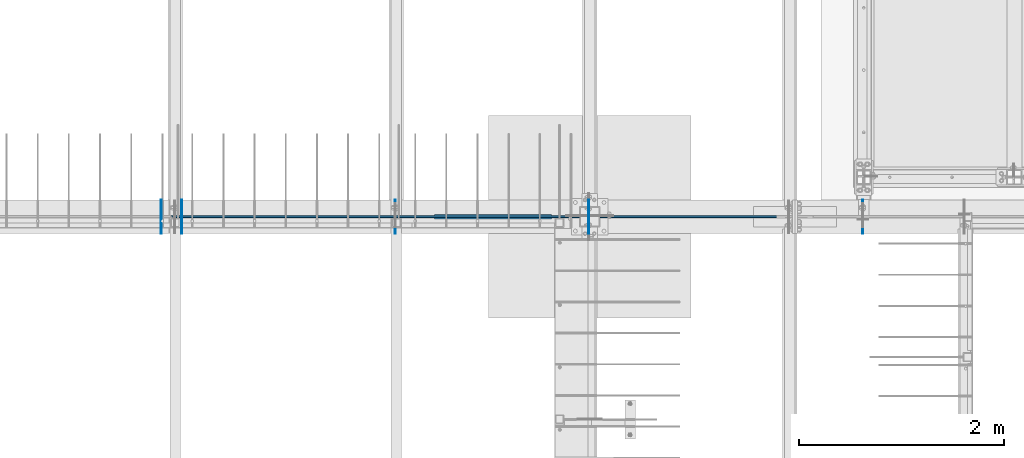
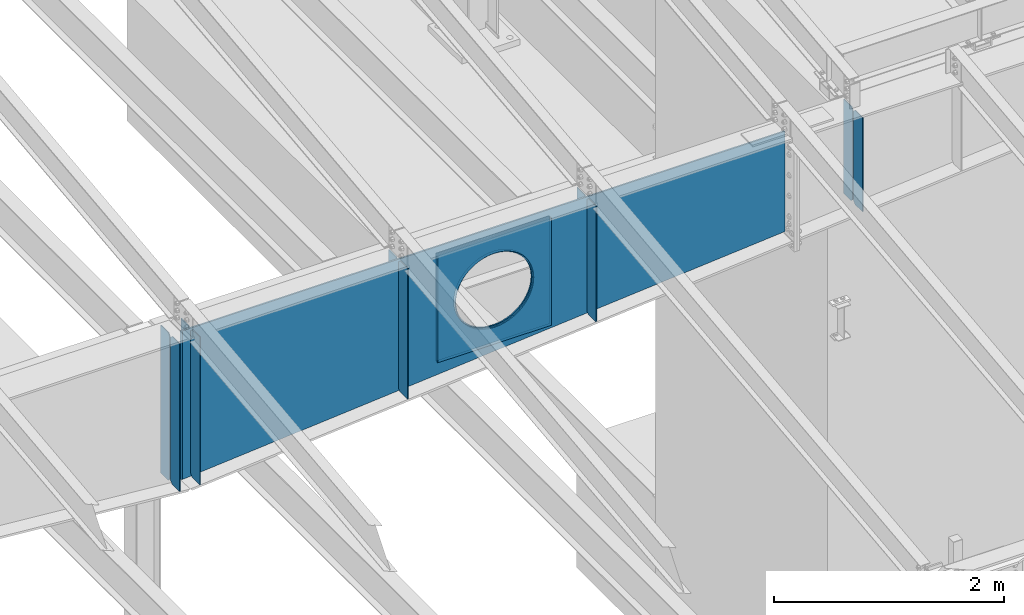
# One storey, part 970 of 1179: 13 plates, 2 elements without a shape of their own.
"""IFC2X3 building model written with IfcOpenShell, lengths in millimetres."""

from ifc_helpers import new_model, si_unit, frame, origin_with_axes, place, context, subcontext, project, spatial, faceted_brep, material, type_object, element, aggregate, save


model = new_model("IFC2X3")

# Units and contexts
model_context = context("Model", 3, precision=1e-05, world=origin_with_axes())
body_context = subcontext(model_context, "Body", "Model", "MODEL_VIEW")
ifc_project = project(units=[si_unit("LENGTHUNIT", "METRE", prefix="MILLI"), si_unit("AREAUNIT", "SQUARE_METRE"), si_unit("VOLUMEUNIT", "CUBIC_METRE"), si_unit("MASSUNIT", "GRAM", prefix="KILO"), si_unit("TIMEUNIT", "SECOND"), si_unit("PLANEANGLEUNIT", "RADIAN"), si_unit("SOLIDANGLEUNIT", "STERADIAN"), si_unit("THERMODYNAMICTEMPERATUREUNIT", "DEGREE_CELSIUS"), si_unit("LUMINOUSINTENSITYUNIT", "LUMEN")], contexts=[model_context])

# Site, building, storey
site_placement = place(None, origin_with_axes())
site = spatial("IfcSite", under=ifc_project, at=site_placement, CompositionType="ELEMENT")
building_placement = place(site_placement, origin_with_axes())
building = spatial("IfcBuilding", under=site, at=building_placement, Name="Undefined", CompositionType="ELEMENT")
storey_placement = place(building_placement, origin_with_axes())
storey = spatial("IfcBuildingStorey", under=building, at=storey_placement, Name="Undefined", CompositionType="ELEMENT", Elevation=0.0)

# Assembly, plates
assembly_1_placement = place(storey_placement, origin_with_axes())
assembly_1 = element("IfcElementAssembly", 1, at=assembly_1_placement, inside=storey, Name="RAFTER BEAM", AssemblyPlace="NOTDEFINED", PredefinedType="RIGID_FRAME")
ifc_material = material(Name="STEEL/A36")
plate_type_1 = type_object("IfcPlateType", PredefinedType="NOTDEFINED")
plate_1_placement = place(assembly_1_placement, frame((14558.9625, 11645.9093353251, 10228.28385672), z_axis=(0.0, 0.0, -1.0), x_axis=(0.0, -1.0, 0.0)))
plate_1 = element("IfcPlate", 2, at=plate_1_placement, type_object=plate_type_1, material=ifc_material, Name="PLATE", context=body_context, shape_type="Brep", body=[
    faceted_brep([(0.0, -4.76249999999709, 0.0), (-3.04256900562905e-06, -4.76250000000073, 1391.55413132619), (-3.04256900562905e-06, 4.76250000000073, 1391.55413132619), (0.0, 4.76249999999709, 0.0), (131.762497338896, -4.76250000000073, 1391.5541316458), (131.762497338896, 4.76250000000073, 1391.5541316458), (157.162497012963, -4.76250000000073, 1366.15413208888), (157.162497012963, 4.76250000000073, 1366.15413208888), (157.162499942613, -4.76250000000073, 25.3999996182793), (157.162499942613, 4.76250000000073, 25.3999996182793), (131.762500381465, -4.76250000000073, -2.09183781407773e-10), (131.762500381465, 4.76250000000073, -2.09183781407773e-10)], [[[0, 1, 2, 3]], [[1, 4, 5, 2]], [[4, 6, 7, 5]], [[6, 8, 9, 7]], [[8, 10, 11, 9]], [[10, 0, 3, 11]], [[5, 7, 9, 11, 3, 2]], [[10, 8, 6, 4, 1, 0]]]),
])
plate_2_placement = place(assembly_1_placement, frame((16451.2625, 11645.9093353251, 10228.28385672), z_axis=(0.0, 0.0, -1.0), x_axis=(0.0, -1.0, 0.0)))
plate_2 = element("IfcPlate", 3, at=plate_2_placement, type_object=plate_type_1, material=ifc_material, Name="PLATE", context=body_context, shape_type="Brep", body=[
    faceted_brep([(0.0, -4.76249999999709, 0.0), (-2.72028773906641e-06, -4.76250000000073, 1230.41295070648), (-2.72028773906641e-06, 4.76250000000073, 1230.41295070648), (0.0, 4.76249999999709, 0.0), (131.762497661177, -4.76250000000073, 1230.41295102609), (131.762497661177, 4.76250000000073, 1230.41295102609), (157.162497335859, -4.76250000000073, 1205.01295146917), (157.162497335859, 4.76250000000073, 1205.01295146917), (157.162499942613, -4.76250000000073, 25.3999996182793), (157.162499942613, 4.76250000000073, 25.3999996182793), (131.762500381465, -4.76250000000073, -2.09183781407773e-10), (131.762500381465, 4.76250000000073, -2.09183781407773e-10)], [[[0, 1, 2, 3]], [[1, 4, 5, 2]], [[4, 6, 7, 5]], [[6, 8, 9, 7]], [[8, 10, 11, 9]], [[10, 0, 3, 11]], [[5, 7, 9, 11, 3, 2]], [[10, 8, 6, 4, 1, 0]]]),
])

# Assembly, plate
assembly_2_placement = place(storey_placement, origin_with_axes())
assembly_2 = element("IfcElementAssembly", 4, at=assembly_2_placement, inside=storey, Name="RAFTER BEAM", AssemblyPlace="NOTDEFINED", PredefinedType="RIGID_FRAME")
plate_3_placement = place(assembly_2_placement, frame((19130.9625, 11645.9093353251, 10228.28385672), z_axis=(0.0, 0.0, -1.0), x_axis=(0.0, -1.0, 0.0)))
plate_3 = element("IfcPlate", 5, at=plate_3_placement, type_object=plate_type_1, material=ifc_material, Name="PLATE", context=body_context, shape_type="Brep", body=[
    faceted_brep([(0.0, -4.76249999999709, 0.0), (-2.26062911679037e-06, -4.76250000000073, 1000.58386493601), (-2.26062911679037e-06, 4.76250000000073, 1000.58386493601), (0.0, 4.76249999999709, 0.0), (131.762498120836, -4.76250000000073, 1000.58386525562), (131.762498120836, 4.76250000000073, 1000.58386525562), (157.162497796751, -4.76250000000073, 975.1838656987), (157.162497796751, 4.76250000000073, 975.1838656987), (157.162499942613, -4.76250000000073, 25.3999996182793), (157.162499942613, 4.76250000000073, 25.3999996182793), (131.762500381465, -4.76250000000073, -2.09183781407773e-10), (131.762500381465, 4.76250000000073, -2.09183781407773e-10)], [[[0, 1, 2, 3]], [[1, 4, 5, 2]], [[4, 6, 7, 5]], [[6, 8, 9, 7]], [[8, 10, 11, 9]], [[10, 0, 3, 11]], [[5, 7, 9, 11, 3, 2]], [[10, 8, 6, 4, 1, 0]]]),
])

# Plate
plate_4_placement = place(assembly_1_placement, frame((14558.9625, 11315.7093353614, 10228.28385672), z_axis=(0.0, 0.0, -1.0), x_axis=(0.0, 1.0, 0.0)))
plate_4 = element("IfcPlate", 6, at=plate_4_placement, type_object=plate_type_1, material=ifc_material, Name="PLATE", context=body_context, shape_type="Brep", body=[
    faceted_brep([(0.0, -4.76249999999709, 0.0), (-3.04256900562905e-06, -4.76250000000073, 1391.55413132619), (-3.04256900562905e-06, 4.76250000000073, 1391.55413132619), (0.0, 4.76249999999709, 0.0), (131.762497338896, -4.76250000000073, 1391.5541316458), (131.762497338896, 4.76250000000073, 1391.5541316458), (157.162497012963, -4.76250000000073, 1366.15413208888), (157.162497012963, 4.76250000000073, 1366.15413208888), (157.162499942613, -4.76250000000073, 25.3999996182793), (157.162499942613, 4.76250000000073, 25.3999996182793), (131.762500381465, -4.76250000000073, -2.09183781407773e-10), (131.762500381465, 4.76250000000073, -2.09183781407773e-10)], [[[0, 1, 2, 3]], [[1, 4, 5, 2]], [[4, 6, 7, 5]], [[6, 8, 9, 7]], [[8, 10, 11, 9]], [[10, 0, 3, 11]], [[5, 7, 9, 11, 3, 2]], [[10, 8, 6, 4, 1, 0]]]),
])

plate_5_placement = place(assembly_1_placement, frame((16451.2625, 11315.7093353614, 10228.28385672), z_axis=(0.0, 0.0, -1.0), x_axis=(0.0, 1.0, 0.0)))
plate_5 = element("IfcPlate", 7, at=plate_5_placement, type_object=plate_type_1, material=ifc_material, Name="PLATE", context=body_context, shape_type="Brep", body=[
    faceted_brep([(0.0, -4.76249999999709, 0.0), (-2.72028773906641e-06, -4.76250000000073, 1230.41295070648), (-2.72028773906641e-06, 4.76250000000073, 1230.41295070648), (0.0, 4.76249999999709, 0.0), (131.762497661177, -4.76250000000073, 1230.41295102609), (131.762497661177, 4.76250000000073, 1230.41295102609), (157.162497335859, -4.76250000000073, 1205.01295146917), (157.162497335859, 4.76250000000073, 1205.01295146917), (157.162499942613, -4.76250000000073, 25.3999996182793), (157.162499942613, 4.76250000000073, 25.3999996182793), (131.762500381465, -4.76250000000073, -2.09183781407773e-10), (131.762500381465, 4.76250000000073, -2.09183781407773e-10)], [[[0, 1, 2, 3]], [[1, 4, 5, 2]], [[4, 6, 7, 5]], [[6, 8, 9, 7]], [[8, 10, 11, 9]], [[10, 0, 3, 11]], [[5, 7, 9, 11, 3, 2]], [[10, 8, 6, 4, 1, 0]]]),
])

plate_6_placement = place(assembly_2_placement, frame((19130.9625, 11315.7093353614, 10228.28385672), z_axis=(0.0, 0.0, -1.0), x_axis=(0.0, 1.0, 0.0)))
plate_6 = element("IfcPlate", 8, at=plate_6_placement, type_object=plate_type_1, material=ifc_material, Name="PLATE", context=body_context, shape_type="Brep", body=[
    faceted_brep([(0.0, -4.76249999999709, 0.0), (-2.26062911679037e-06, -4.76250000000073, 1000.58386493601), (-2.26062911679037e-06, 4.76250000000073, 1000.58386493601), (0.0, 4.76249999999709, 0.0), (131.762498120836, -4.76250000000073, 1000.58386525562), (131.762498120836, 4.76250000000073, 1000.58386525562), (157.162497796751, -4.76250000000073, 975.1838656987), (157.162497796751, 4.76250000000073, 975.1838656987), (157.162499942613, -4.76250000000073, 25.3999996182793), (157.162499942613, 4.76250000000073, 25.3999996182793), (131.762500381465, -4.76250000000073, -2.09183781407773e-10), (131.762500381465, 4.76250000000073, -2.09183781407773e-10)], [[[0, 1, 2, 3]], [[1, 4, 5, 2]], [[4, 6, 7, 5]], [[6, 8, 9, 7]], [[8, 10, 11, 9]], [[10, 0, 3, 11]], [[5, 7, 9, 11, 3, 2]], [[10, 8, 6, 4, 1, 0]]]),
])

aggregate(assembly_2, [plate_3, plate_6])

plate_7_placement = place(assembly_1_placement, frame((12471.4000000016, 11488.7468292579, 10228.2872380677), z_axis=(0.0, 0.0, -1.0), x_axis=(0.0, 1.0, 0.0)))
plate_7 = element("IfcPlate", 9, at=plate_7_placement, type_object=plate_type_1, material=ifc_material, Name="PLATE", context=body_context, shape_type="Brep", body=[
    faceted_brep([(0.0, -4.76250000000073, 25.3999996185303), (0.0, -4.76250000000073, 1543.92653032954), (0.0, 4.76250000000073, 1543.92653032954), (0.0, 4.76250000000073, 25.3999996185303), (25.3999996185303, -4.76250000000073, 1569.32652994807), (25.3999996185303, 4.76250000000073, 1569.32652994807), (157.162506103516, -4.76250000000073, 1569.32652994807), (157.162506103516, 4.76250000000073, 1569.32652994807), (157.162506103516, -4.76250000000073, 0.0), (157.162506103516, 4.76250000000073, 0.0), (25.3999996185303, -4.76250000000073, 0.0), (25.3999996185303, 4.76250000000073, 0.0)], [[[0, 1, 2, 3]], [[1, 4, 5, 2]], [[4, 6, 7, 5]], [[6, 8, 9, 7]], [[8, 10, 11, 9]], [[10, 0, 3, 11]], [[5, 7, 9, 11, 3, 2]], [[10, 8, 6, 4, 1, 0]]]),
])

plate_8_placement = place(assembly_1_placement, frame((12471.4000000016, 11472.8718414649, 10228.2872380677), z_axis=(0.0, 0.0, -1.0), x_axis=(0.0, -1.0, 0.0)))
plate_8 = element("IfcPlate", 10, at=plate_8_placement, type_object=plate_type_1, material=ifc_material, Name="PLATE", context=body_context, shape_type="Brep", body=[
    faceted_brep([(0.0, -4.76250000000073, 25.3999996185303), (0.0, -4.76250000000073, 1543.92653032954), (0.0, 4.76250000000073, 1543.92653032954), (0.0, 4.76250000000073, 25.3999996185303), (25.3999996185303, -4.76250000000073, 1569.32652994807), (25.3999996185303, 4.76250000000073, 1569.32652994807), (157.162506103516, -4.76250000000073, 1569.32652994807), (157.162506103516, 4.76250000000073, 1569.32652994807), (157.162506103516, -4.76250000000073, 0.0), (157.162506103516, 4.76250000000073, 0.0), (25.3999996185303, -4.76250000000073, 0.0), (25.3999996185303, 4.76250000000073, 0.0)], [[[0, 1, 2, 3]], [[1, 4, 5, 2]], [[4, 6, 7, 5]], [[6, 8, 9, 7]], [[8, 10, 11, 9]], [[10, 0, 3, 11]], [[5, 7, 9, 11, 3, 2]], [[10, 8, 6, 4, 1, 0]]]),
])

plate_9_placement = place(assembly_1_placement, frame((12268.2000000016, 11488.7468231544, 10228.2872380677), z_axis=(0.0, 0.0, -1.0), x_axis=(0.0, 1.0, 0.0)))
plate_9 = element("IfcPlate", 11, at=plate_9_placement, type_object=plate_type_1, material=ifc_material, Name="PLATE", context=body_context, shape_type="Brep", body=[
    faceted_brep([(0.0, -4.76250000000073, 25.3999996185303), (0.0, -4.76250000000073, 1543.92653032954), (0.0, 4.76250000000073, 1543.92653032954), (0.0, 4.76250000000073, 25.3999996185303), (25.3999996185303, -4.76250000000073, 1569.32652994807), (25.3999996185303, 4.76250000000073, 1569.32652994807), (157.162506103516, -4.76250000000073, 1569.32652994807), (157.162506103516, 4.76250000000073, 1569.32652994807), (157.162506103516, -4.76250000000073, 0.0), (157.162506103516, 4.76250000000073, 0.0), (25.3999996185303, -4.76250000000073, 0.0), (25.3999996185303, 4.76250000000073, 0.0)], [[[0, 1, 2, 3]], [[1, 4, 5, 2]], [[4, 6, 7, 5]], [[6, 8, 9, 7]], [[8, 10, 11, 9]], [[10, 0, 3, 11]], [[5, 7, 9, 11, 3, 2]], [[10, 8, 6, 4, 1, 0]]]),
])

plate_10_placement = place(assembly_1_placement, frame((12268.2000000016, 11472.8718353614, 10228.2872380677), z_axis=(0.0, 0.0, -1.0), x_axis=(0.0, -1.0, 0.0)))
plate_10 = element("IfcPlate", 12, at=plate_10_placement, type_object=plate_type_1, material=ifc_material, Name="PLATE", context=body_context, shape_type="Brep", body=[
    faceted_brep([(0.0, -4.76250000000073, 25.3999996185303), (0.0, -4.76250000000073, 1543.92653032954), (0.0, 4.76250000000073, 1543.92653032954), (0.0, 4.76250000000073, 25.3999996185303), (25.3999996185303, -4.76250000000073, 1569.32652994807), (25.3999996185303, 4.76250000000073, 1569.32652994807), (157.162506103516, -4.76250000000073, 1569.32652994807), (157.162506103516, 4.76250000000073, 1569.32652994807), (157.162506103516, -4.76250000000073, 0.0), (157.162506103516, 4.76250000000073, 0.0), (25.3999996185303, -4.76250000000073, 0.0), (25.3999996185303, 4.76250000000073, 0.0)], [[[0, 1, 2, 3]], [[1, 4, 5, 2]], [[4, 6, 7, 5]], [[6, 8, 9, 7]], [[8, 10, 11, 9]], [[10, 0, 3, 11]], [[5, 7, 9, 11, 3, 2]], [[10, 8, 6, 4, 1, 0]]]),
])

plate_type_2 = type_object("IfcPlateType", PredefinedType="NOTDEFINED")
plate_11_placement = place(assembly_1_placement, frame((16084.55, 11495.0968353614, 10144.6300485077), z_axis=(0.0, 0.0, -1.0), x_axis=(-1.0, 0.0, 0.0)))
plate_11 = element("IfcPlate", 13, at=plate_11_placement, type_object=plate_type_2, material=ifc_material, Name="PLATE", context=body_context, shape_type="Brep", body=[
    faceted_brep([(961.831841922869, -6.35000000000036, 520.111838122966), (961.831841922869, 6.35000000000036, 520.111838122966), (951.784997810006, 6.35000000000036, 469.602941943138), (951.784997810006, -6.35000000000036, 469.602941943138), (935.231371949694, 6.35000000000036, 420.837532677864), (935.231371949694, -6.35000000000036, 420.837532677864), (912.454201469933, 6.35000000000036, 374.65), (912.454201469933, -6.35000000000036, 374.65), (883.843210072659, 6.35000000000036, 331.830625399267), (883.843210072659, -6.35000000000036, 331.830625399267), (849.887939753144, 6.35000000000036, 293.112060246856), (849.887939753144, -6.35000000000036, 293.112060246856), (811.169374600733, 6.35000000000036, 259.156789927341), (811.169374600733, -6.35000000000036, 259.156789927341), (768.35, 6.35000000000036, 230.545798530067), (768.35, -6.35000000000036, 230.545798530067), (722.162467322136, 6.35000000000036, 207.768628050306), (722.162467322136, -6.35000000000036, 207.768628050306), (673.397058056862, 6.35000000000036, 191.215002189994), (673.397058056862, -6.35000000000036, 191.215002189994), (622.888161877034, 6.35000000000036, 181.168158077131), (622.888161877034, -6.35000000000036, 181.168158077131), (571.5, 6.35000000000036, 177.799999999999), (571.5, -6.35000000000036, 177.799999999999), (520.111838122966, 6.35000000000036, 181.168158077131), (520.111838122966, -6.35000000000036, 181.168158077131), (469.602941943138, 6.35000000000036, 191.215002189994), (469.602941943138, -6.35000000000036, 191.215002189994), (420.837532677864, 6.35000000000036, 207.768628050306), (420.837532677864, -6.35000000000036, 207.768628050306), (374.65, 6.35000000000036, 230.545798530067), (374.65, -6.35000000000036, 230.545798530067), (331.830625399267, 6.35000000000036, 259.156789927341), (331.830625399267, -6.35000000000036, 259.156789927341), (293.112060246856, 6.35000000000036, 293.112060246856), (293.112060246856, -6.35000000000036, 293.112060246856), (259.156789927341, 6.35000000000036, 331.830625399267), (259.156789927341, -6.35000000000036, 331.830625399267), (230.545798530067, 6.35000000000036, 374.65), (230.545798530067, -6.35000000000036, 374.65), (207.768628050306, 6.35000000000036, 420.837532677864), (207.768628050306, -6.35000000000036, 420.837532677864), (191.215002189994, 6.35000000000036, 469.602941943138), (191.215002189994, -6.35000000000036, 469.602941943138), (181.168158077131, 6.35000000000036, 520.111838122966), (181.168158077131, -6.35000000000036, 520.111838122966), (177.799999999999, 6.35000000000036, 571.5), (177.799999999999, -6.35000000000036, 571.5), (181.168158077131, 6.35000000000036, 622.888161877036), (181.168158077131, -6.35000000000036, 622.888161877036), (191.215002189994, 6.35000000000036, 673.397058056862), (191.215002189994, -6.35000000000036, 673.397058056862), (207.768628050306, 6.35000000000036, 722.162467322136), (207.768628050306, -6.35000000000036, 722.162467322136), (230.545798530067, 6.35000000000036, 768.35), (230.545798530067, -6.35000000000036, 768.35), (259.156789927341, 6.35000000000036, 811.169374600733), (259.156789927341, -6.35000000000036, 811.169374600733), (293.112060246856, 6.35000000000036, 849.887939753144), (293.112060246856, -6.35000000000036, 849.887939753144), (331.830625399267, 6.35000000000036, 883.84321007266), (331.830625399267, -6.35000000000036, 883.84321007266), (374.65, 6.35000000000036, 912.454201469933), (374.65, -6.35000000000036, 912.454201469933), (420.837532677864, 6.35000000000036, 935.231371949694), (420.837532677864, -6.35000000000036, 935.231371949694), (469.602941943138, 6.35000000000036, 951.784997810006), (469.602941943138, -6.35000000000036, 951.784997810006), (520.111838122966, 6.35000000000036, 961.831841922869), (520.111838122966, -6.35000000000036, 961.831841922869), (571.5, 6.35000000000036, 965.200000000001), (571.5, -6.35000000000036, 965.200000000001), (622.888161877034, 6.35000000000036, 961.831841922869), (622.888161877034, -6.35000000000036, 961.831841922869), (673.397058056862, 6.35000000000036, 951.784997810006), (673.397058056862, -6.35000000000036, 951.784997810006), (722.162467322136, 6.35000000000036, 935.231371949694), (722.162467322136, -6.35000000000036, 935.231371949694), (768.35, 6.35000000000036, 912.454201469933), (768.35, -6.35000000000036, 912.454201469933), (811.169374600733, 6.35000000000036, 883.843210072659), (811.169374600733, -6.35000000000036, 883.843210072659), (849.887939753144, 6.35000000000036, 849.887939753144), (849.887939753144, -6.35000000000036, 849.887939753144), (883.843210072659, 6.35000000000036, 811.169374600733), (883.843210072659, -6.35000000000036, 811.169374600733), (912.454201469933, 6.35000000000036, 768.35), (912.454201469933, -6.35000000000036, 768.35), (935.231371949694, 6.35000000000036, 722.162467322136), (935.231371949694, -6.35000000000036, 722.162467322136), (951.784997810006, 6.35000000000036, 673.397058056862), (951.784997810006, -6.35000000000036, 673.397058056862), (961.831841922869, 6.35000000000036, 622.888161877034), (961.831841922869, -6.35000000000036, 622.888161877034), (965.200000000001, 6.35000000000036, 571.5), (965.200000000001, -6.35000000000036, 571.5), (1143.0, -6.35000000000036, 0.0), (1143.0, -6.35000000000036, 1143.0), (0.0, -6.35000000000036, 1143.0), (0.0, -6.34999999999854, 0.0), (0.0, 6.34999999999854, 0.0), (1143.0, 6.35000000000036, 0.0), (1143.0, 6.35000000000036, 1143.0), (0.0, 6.35000000000036, 1143.0)], [[[0, 1, 2, 3]], [[3, 2, 4, 5]], [[5, 4, 6, 7]], [[7, 6, 8, 9]], [[9, 8, 10, 11]], [[11, 10, 12, 13]], [[13, 12, 14, 15]], [[15, 14, 16, 17]], [[17, 16, 18, 19]], [[19, 18, 20, 21]], [[21, 20, 22, 23]], [[23, 22, 24, 25]], [[25, 24, 26, 27]], [[27, 26, 28, 29]], [[29, 28, 30, 31]], [[31, 30, 32, 33]], [[33, 32, 34, 35]], [[35, 34, 36, 37]], [[37, 36, 38, 39]], [[39, 38, 40, 41]], [[41, 40, 42, 43]], [[43, 42, 44, 45]], [[45, 44, 46, 47]], [[47, 46, 48, 49]], [[49, 48, 50, 51]], [[51, 50, 52, 53]], [[53, 52, 54, 55]], [[55, 54, 56, 57]], [[57, 56, 58, 59]], [[59, 58, 60, 61]], [[61, 60, 62, 63]], [[63, 62, 64, 65]], [[65, 64, 66, 67]], [[67, 66, 68, 69]], [[69, 68, 70, 71]], [[71, 70, 72, 73]], [[73, 72, 74, 75]], [[75, 74, 76, 77]], [[77, 76, 78, 79]], [[79, 78, 80, 81]], [[81, 80, 82, 83]], [[83, 82, 84, 85]], [[85, 84, 86, 87]], [[87, 86, 88, 89]], [[89, 88, 90, 91]], [[91, 90, 92, 93]], [[93, 92, 94, 95]], [[95, 94, 1, 0]], [[96, 97, 98, 99], [3, 5, 7, 9, 11, 13, 15, 17, 19, 21, 23, 25, 27, 29, 31, 33, 35, 37, 39, 41, 43, 45, 47, 49, 51, 53, 55, 57, 59, 61, 63, 65, 67, 69, 71, 73, 75, 77, 79, 81, 83, 85, 87, 89, 91, 93, 95, 0]], [[96, 99, 100, 101]], [[97, 96, 101, 102]], [[98, 97, 102, 103]], [[99, 98, 103, 100]], [[102, 101, 100, 103], [90, 88, 86, 84, 82, 80, 78, 76, 74, 72, 70, 68, 66, 64, 62, 60, 58, 56, 54, 52, 50, 48, 46, 44, 42, 40, 38, 36, 34, 32, 30, 28, 26, 24, 22, 20, 18, 16, 14, 12, 10, 8, 6, 4, 2, 1, 94, 92]]]),
])

plate_12_placement = place(assembly_1_placement, frame((16084.55, 11466.5218353614, 10144.6300485077), z_axis=(0.0, 0.0, -1.0), x_axis=(-1.0, 0.0, 0.0)))
plate_12 = element("IfcPlate", 14, at=plate_12_placement, type_object=plate_type_2, material=ifc_material, Name="PLATE", context=body_context, shape_type="Brep", body=[
    faceted_brep([(961.831841922869, -6.35000000000036, 520.111838122966), (961.831841922869, 6.35000000000036, 520.111838122966), (951.784997810006, 6.35000000000036, 469.602941943138), (951.784997810006, -6.35000000000036, 469.602941943138), (935.231371949694, 6.35000000000036, 420.837532677864), (935.231371949694, -6.35000000000036, 420.837532677864), (912.454201469933, 6.35000000000036, 374.65), (912.454201469933, -6.35000000000036, 374.65), (883.843210072659, 6.35000000000036, 331.830625399267), (883.843210072659, -6.35000000000036, 331.830625399267), (849.887939753144, 6.35000000000036, 293.112060246856), (849.887939753144, -6.35000000000036, 293.112060246856), (811.169374600733, 6.35000000000036, 259.156789927341), (811.169374600733, -6.35000000000036, 259.156789927341), (768.35, 6.35000000000036, 230.545798530067), (768.35, -6.35000000000036, 230.545798530067), (722.162467322136, 6.35000000000036, 207.768628050306), (722.162467322136, -6.35000000000036, 207.768628050306), (673.397058056862, 6.35000000000036, 191.215002189994), (673.397058056862, -6.35000000000036, 191.215002189994), (622.888161877034, 6.35000000000036, 181.168158077131), (622.888161877034, -6.35000000000036, 181.168158077131), (571.5, 6.35000000000036, 177.799999999999), (571.5, -6.35000000000036, 177.799999999999), (520.111838122966, 6.35000000000036, 181.168158077131), (520.111838122966, -6.35000000000036, 181.168158077131), (469.602941943138, 6.35000000000036, 191.215002189994), (469.602941943138, -6.35000000000036, 191.215002189994), (420.837532677864, 6.35000000000036, 207.768628050306), (420.837532677864, -6.35000000000036, 207.768628050306), (374.65, 6.35000000000036, 230.545798530067), (374.65, -6.35000000000036, 230.545798530067), (331.830625399267, 6.35000000000036, 259.156789927341), (331.830625399267, -6.35000000000036, 259.156789927341), (293.112060246856, 6.35000000000036, 293.112060246856), (293.112060246856, -6.35000000000036, 293.112060246856), (259.156789927341, 6.35000000000036, 331.830625399267), (259.156789927341, -6.35000000000036, 331.830625399267), (230.545798530067, 6.35000000000036, 374.65), (230.545798530067, -6.35000000000036, 374.65), (207.768628050306, 6.35000000000036, 420.837532677864), (207.768628050306, -6.35000000000036, 420.837532677864), (191.215002189994, 6.35000000000036, 469.602941943138), (191.215002189994, -6.35000000000036, 469.602941943138), (181.168158077131, 6.35000000000036, 520.111838122966), (181.168158077131, -6.35000000000036, 520.111838122966), (177.799999999999, 6.35000000000036, 571.5), (177.799999999999, -6.35000000000036, 571.5), (181.168158077131, 6.35000000000036, 622.888161877036), (181.168158077131, -6.35000000000036, 622.888161877036), (191.215002189994, 6.35000000000036, 673.397058056862), (191.215002189994, -6.35000000000036, 673.397058056862), (207.768628050306, 6.35000000000036, 722.162467322136), (207.768628050306, -6.35000000000036, 722.162467322136), (230.545798530067, 6.35000000000036, 768.35), (230.545798530067, -6.35000000000036, 768.35), (259.156789927341, 6.35000000000036, 811.169374600733), (259.156789927341, -6.35000000000036, 811.169374600733), (293.112060246856, 6.35000000000036, 849.887939753144), (293.112060246856, -6.35000000000036, 849.887939753144), (331.830625399267, 6.35000000000036, 883.84321007266), (331.830625399267, -6.35000000000036, 883.84321007266), (374.65, 6.35000000000036, 912.454201469933), (374.65, -6.35000000000036, 912.454201469933), (420.837532677864, 6.35000000000036, 935.231371949694), (420.837532677864, -6.35000000000036, 935.231371949694), (469.602941943138, 6.35000000000036, 951.784997810006), (469.602941943138, -6.35000000000036, 951.784997810006), (520.111838122966, 6.35000000000036, 961.831841922869), (520.111838122966, -6.35000000000036, 961.831841922869), (571.5, 6.35000000000036, 965.200000000001), (571.5, -6.35000000000036, 965.200000000001), (622.888161877034, 6.35000000000036, 961.831841922869), (622.888161877034, -6.35000000000036, 961.831841922869), (673.397058056862, 6.35000000000036, 951.784997810006), (673.397058056862, -6.35000000000036, 951.784997810006), (722.162467322136, 6.35000000000036, 935.231371949694), (722.162467322136, -6.35000000000036, 935.231371949694), (768.35, 6.35000000000036, 912.454201469933), (768.35, -6.35000000000036, 912.454201469933), (811.169374600733, 6.35000000000036, 883.843210072659), (811.169374600733, -6.35000000000036, 883.843210072659), (849.887939753144, 6.35000000000036, 849.887939753144), (849.887939753144, -6.35000000000036, 849.887939753144), (883.843210072659, 6.35000000000036, 811.169374600733), (883.843210072659, -6.35000000000036, 811.169374600733), (912.454201469933, 6.35000000000036, 768.35), (912.454201469933, -6.35000000000036, 768.35), (935.231371949694, 6.35000000000036, 722.162467322136), (935.231371949694, -6.35000000000036, 722.162467322136), (951.784997810006, 6.35000000000036, 673.397058056862), (951.784997810006, -6.35000000000036, 673.397058056862), (961.831841922869, 6.35000000000036, 622.888161877034), (961.831841922869, -6.35000000000036, 622.888161877034), (965.200000000001, 6.35000000000036, 571.5), (965.200000000001, -6.35000000000036, 571.5), (1143.0, -6.35000000000036, 0.0), (1143.0, -6.35000000000036, 1143.0), (0.0, -6.35000000000036, 1143.0), (0.0, -6.34999999999854, 0.0), (0.0, 6.34999999999854, 0.0), (1143.0, 6.35000000000036, 0.0), (1143.0, 6.35000000000036, 1143.0), (0.0, 6.35000000000036, 1143.0)], [[[0, 1, 2, 3]], [[3, 2, 4, 5]], [[5, 4, 6, 7]], [[7, 6, 8, 9]], [[9, 8, 10, 11]], [[11, 10, 12, 13]], [[13, 12, 14, 15]], [[15, 14, 16, 17]], [[17, 16, 18, 19]], [[19, 18, 20, 21]], [[21, 20, 22, 23]], [[23, 22, 24, 25]], [[25, 24, 26, 27]], [[27, 26, 28, 29]], [[29, 28, 30, 31]], [[31, 30, 32, 33]], [[33, 32, 34, 35]], [[35, 34, 36, 37]], [[37, 36, 38, 39]], [[39, 38, 40, 41]], [[41, 40, 42, 43]], [[43, 42, 44, 45]], [[45, 44, 46, 47]], [[47, 46, 48, 49]], [[49, 48, 50, 51]], [[51, 50, 52, 53]], [[53, 52, 54, 55]], [[55, 54, 56, 57]], [[57, 56, 58, 59]], [[59, 58, 60, 61]], [[61, 60, 62, 63]], [[63, 62, 64, 65]], [[65, 64, 66, 67]], [[67, 66, 68, 69]], [[69, 68, 70, 71]], [[71, 70, 72, 73]], [[73, 72, 74, 75]], [[75, 74, 76, 77]], [[77, 76, 78, 79]], [[79, 78, 80, 81]], [[81, 80, 82, 83]], [[83, 82, 84, 85]], [[85, 84, 86, 87]], [[87, 86, 88, 89]], [[89, 88, 90, 91]], [[91, 90, 92, 93]], [[93, 92, 94, 95]], [[95, 94, 1, 0]], [[96, 97, 98, 99], [3, 5, 7, 9, 11, 13, 15, 17, 19, 21, 23, 25, 27, 29, 31, 33, 35, 37, 39, 41, 43, 45, 47, 49, 51, 53, 55, 57, 59, 61, 63, 65, 67, 69, 71, 73, 75, 77, 79, 81, 83, 85, 87, 89, 91, 93, 95, 0]], [[96, 99, 100, 101]], [[97, 96, 101, 102]], [[98, 97, 102, 103]], [[99, 98, 103, 100]], [[102, 101, 100, 103], [90, 88, 86, 84, 82, 80, 78, 76, 74, 72, 70, 68, 66, 64, 62, 60, 58, 56, 54, 52, 50, 48, 46, 44, 42, 40, 38, 36, 34, 32, 30, 28, 26, 24, 22, 20, 18, 16, 14, 12, 10, 8, 6, 4, 2, 1, 94, 92]]]),
])

plate_type_3 = type_object("IfcPlateType", PredefinedType="NOTDEFINED")
plate_13_placement = place(assembly_1_placement, frame((18465.8, 11480.8093353614, 10229.87135672), z_axis=(0.0, 0.0, -1.0), x_axis=(-1.0, 0.0, 0.0)))
plate_13 = element("IfcPlate", 15, at=plate_13_placement, type_object=plate_type_3, material=ifc_material, Name="RAFTER BEAM", context=body_context, shape_type="Brep", body=[
    faceted_brep([(3330.49049218342, -7.9375, 607.010828976441), (3330.49049218342, 7.9375, 607.010828976441), (3320.76773981614, 7.9375, 558.131252028219), (3320.76773981614, -7.9375, 558.131252028219), (3304.7481018868, 7.9375, 510.938920481181), (3304.7481018868, -7.9375, 510.938920481181), (3282.70567884187, 7.9375, 466.24130821228), (3282.70567884187, -7.9375, 466.24130821228), (3255.01762265096, 7.9375, 424.803203759957), (3255.01762265096, -7.9375, 424.803203759957), (3222.15768363208, 7.9375, 387.333624580206), (3222.15768363208, -7.9375, 387.333624580206), (3184.68810445233, 7.9375, 354.473685561319), (3184.68810445233, -7.9375, 354.473685561319), (3143.25, 7.9375, 326.78562937041), (3143.25, -7.9375, 326.78562937041), (3098.5523877311, 7.9375, 304.74320632548), (3098.5523877311, -7.9375, 304.74320632548), (3051.36005618406, 7.9375, 288.723568396144), (3051.36005618406, -7.9375, 288.723568396144), (3002.48047923584, 7.9375, 279.000816028858), (3002.48047923584, -7.9375, 279.000816028858), (2952.75, 7.9375, 275.74130821228), (2952.75, -7.9375, 275.74130821228), (2903.01952076416, 7.9375, 279.000816028858), (2903.01952076416, -7.9375, 279.000816028858), (2854.13994381594, 7.9375, 288.723568396144), (2854.13994381594, -7.9375, 288.723568396144), (2806.9476122689, 7.9375, 304.74320632548), (2806.9476122689, -7.9375, 304.74320632548), (2762.25, 7.9375, 326.78562937041), (2762.25, -7.9375, 326.78562937041), (2720.81189554768, 7.9375, 354.473685561319), (2720.81189554768, -7.9375, 354.473685561319), (2683.34231636793, 7.9375, 387.333624580206), (2683.34231636793, -7.9375, 387.333624580206), (2650.48237734904, 7.9375, 424.803203759957), (2650.48237734904, -7.9375, 424.803203759957), (2622.79432115813, 7.9375, 466.24130821228), (2622.79432115813, -7.9375, 466.24130821228), (2600.7518981132, 7.9375, 510.938920481181), (2600.7518981132, -7.9375, 510.938920481181), (2584.73226018387, 7.9375, 558.131252028219), (2584.73226018387, -7.9375, 558.131252028219), (2575.00950781658, 7.9375, 607.010828976441), (2575.00950781658, -7.9375, 607.010828976441), (2571.75, 7.9375, 656.74130821228), (2571.75, -7.9375, 656.74130821228), (2575.00950781658, 7.9375, 706.471787448121), (2575.00950781658, -7.9375, 706.471787448121), (2584.73226018387, 7.9375, 755.351364396342), (2584.73226018387, -7.9375, 755.351364396342), (2600.7518981132, 7.9375, 802.543695943379), (2600.7518981132, -7.9375, 802.543695943379), (2622.79432115813, 7.9375, 847.24130821228), (2622.79432115813, -7.9375, 847.24130821228), (2650.48237734904, 7.9375, 888.679412664604), (2650.48237734904, -7.9375, 888.679412664604), (2683.34231636793, 7.9375, 926.148991844355), (2683.34231636793, -7.9375, 926.148991844355), (2720.81189554768, 7.9375, 959.008930863241), (2720.81189554768, -7.9375, 959.008930863241), (2762.25, 7.9375, 986.696987054151), (2762.25, -7.9375, 986.696987054151), (2806.9476122689, 7.9375, 1008.73941009908), (2806.9476122689, -7.9375, 1008.73941009908), (2854.13994381594, 7.9375, 1024.75904802842), (2854.13994381594, -7.9375, 1024.75904802842), (2903.01952076416, 7.9375, 1034.4818003957), (2903.01952076416, -7.9375, 1034.4818003957), (2952.75, 7.9375, 1037.74130821228), (2952.75, -7.9375, 1037.74130821228), (3002.48047923584, 7.9375, 1034.4818003957), (3002.48047923584, -7.9375, 1034.4818003957), (3051.36005618406, 7.9375, 1024.75904802842), (3051.36005618406, -7.9375, 1024.75904802842), (3098.5523877311, 7.9375, 1008.73941009908), (3098.5523877311, -7.9375, 1008.73941009908), (3143.25, 7.9375, 986.696987054151), (3143.25, -7.9375, 986.696987054151), (3184.68810445233, 7.9375, 959.008930863241), (3184.68810445233, -7.9375, 959.008930863241), (3222.15768363208, 7.9375, 926.148991844355), (3222.15768363208, -7.9375, 926.148991844355), (3255.01762265096, 7.9375, 888.679412664602), (3255.01762265096, -7.9375, 888.679412664602), (3282.70567884187, 7.9375, 847.24130821228), (3282.70567884187, -7.9375, 847.24130821228), (3304.7481018868, 7.9375, 802.543695943379), (3304.7481018868, -7.9375, 802.543695943379), (3320.76773981614, 7.9375, 755.35136439634), (3320.76773981614, -7.9375, 755.35136439634), (3330.49049218342, 7.9375, 706.471787448119), (3330.49049218342, -7.9375, 706.471787448119), (3333.75, 7.9375, 656.74130821228), (3333.75, -7.9375, 656.74130821228), (6080.125, -7.9375, 0.0), (6080.125, -7.9375, 1579.79816881816), (25.3999999990338, -7.9375, 1064.20044453931), (25.4000000002561, -7.9375, 0.0), (6096.0, 7.9375, 0.0), (25.4000000002561, 7.9375, 0.0), (6096.0, 7.9375, 1581.15002441406), (25.3999999990338, 7.9375, 1064.20044453931)], [[[0, 1, 2, 3]], [[3, 2, 4, 5]], [[5, 4, 6, 7]], [[7, 6, 8, 9]], [[9, 8, 10, 11]], [[11, 10, 12, 13]], [[13, 12, 14, 15]], [[15, 14, 16, 17]], [[17, 16, 18, 19]], [[19, 18, 20, 21]], [[21, 20, 22, 23]], [[23, 22, 24, 25]], [[25, 24, 26, 27]], [[27, 26, 28, 29]], [[29, 28, 30, 31]], [[31, 30, 32, 33]], [[33, 32, 34, 35]], [[35, 34, 36, 37]], [[37, 36, 38, 39]], [[39, 38, 40, 41]], [[41, 40, 42, 43]], [[43, 42, 44, 45]], [[45, 44, 46, 47]], [[47, 46, 48, 49]], [[49, 48, 50, 51]], [[51, 50, 52, 53]], [[53, 52, 54, 55]], [[55, 54, 56, 57]], [[57, 56, 58, 59]], [[59, 58, 60, 61]], [[61, 60, 62, 63]], [[63, 62, 64, 65]], [[65, 64, 66, 67]], [[67, 66, 68, 69]], [[69, 68, 70, 71]], [[71, 70, 72, 73]], [[73, 72, 74, 75]], [[75, 74, 76, 77]], [[77, 76, 78, 79]], [[79, 78, 80, 81]], [[81, 80, 82, 83]], [[83, 82, 84, 85]], [[85, 84, 86, 87]], [[87, 86, 88, 89]], [[89, 88, 90, 91]], [[91, 90, 92, 93]], [[93, 92, 94, 95]], [[95, 94, 1, 0]], [[96, 97, 98, 99], [3, 5, 7, 9, 11, 13, 15, 17, 19, 21, 23, 25, 27, 29, 31, 33, 35, 37, 39, 41, 43, 45, 47, 49, 51, 53, 55, 57, 59, 61, 63, 65, 67, 69, 71, 73, 75, 77, 79, 81, 83, 85, 87, 89, 91, 93, 95, 0]], [[100, 96, 99, 101]], [[102, 97, 96, 100]], [[97, 102, 103, 98]], [[101, 99, 98, 103]], [[102, 100, 101, 103], [90, 88, 86, 84, 82, 80, 78, 76, 74, 72, 70, 68, 66, 64, 62, 60, 58, 56, 54, 52, 50, 48, 46, 44, 42, 40, 38, 36, 34, 32, 30, 28, 26, 24, 22, 20, 18, 16, 14, 12, 10, 8, 6, 4, 2, 1, 94, 92]]]),
])

aggregate(assembly_1, [plate_1, plate_2, plate_4, plate_5, plate_11, plate_12, plate_7, plate_8, plate_9, plate_10, plate_13])

save(model, "model.ifc")
